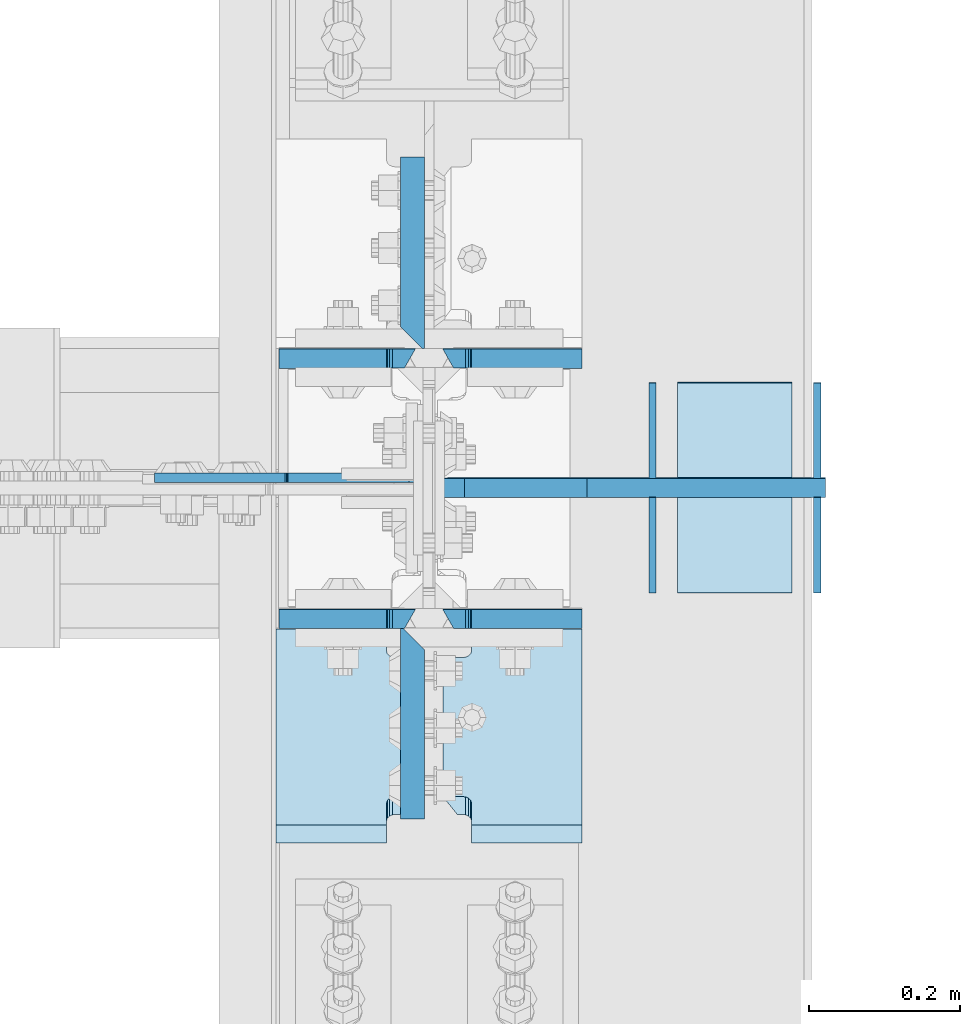
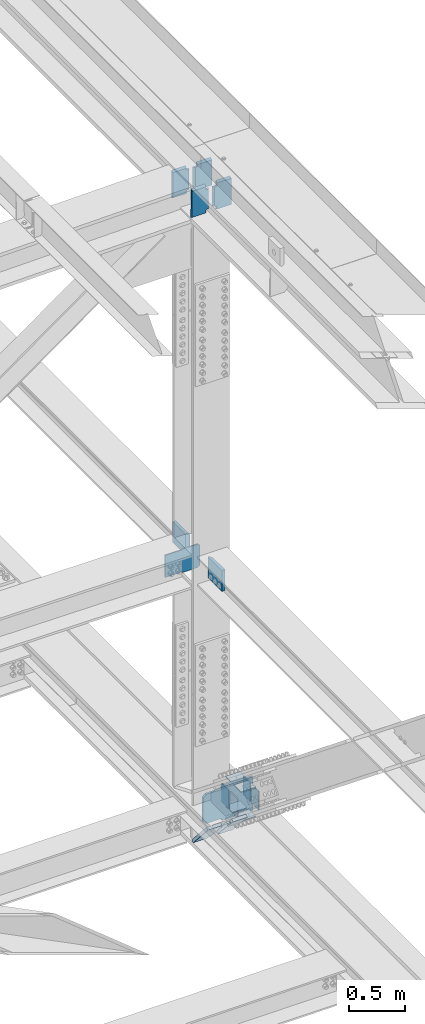
# One storey, part 3594 of 3843: 18 plates, 11 elements without a shape of their own.
"""IFC2X3 building model written with IfcOpenShell, lengths in millimetres."""

from ifc_helpers import new_model, si_unit, frame, origin_with_axes, place, context, subcontext, project, spatial, faceted_brep, material, type_object, element, aggregate, save


model = new_model("IFC2X3")

# Units and contexts
model_context = context("Model", 3, precision=1e-05, world=origin_with_axes())
body_context = subcontext(model_context, "Body", "Model", "MODEL_VIEW")
ifc_project = project(units=[si_unit("LENGTHUNIT", "METRE", prefix="MILLI"), si_unit("AREAUNIT", "SQUARE_METRE"), si_unit("VOLUMEUNIT", "CUBIC_METRE"), si_unit("MASSUNIT", "GRAM", prefix="KILO"), si_unit("TIMEUNIT", "SECOND"), si_unit("PLANEANGLEUNIT", "RADIAN"), si_unit("SOLIDANGLEUNIT", "STERADIAN"), si_unit("THERMODYNAMICTEMPERATUREUNIT", "DEGREE_CELSIUS"), si_unit("LUMINOUSINTENSITYUNIT", "LUMEN")], contexts=[model_context])

# Site, building, storey
site_placement = place(None, origin_with_axes())
site = spatial("IfcSite", under=ifc_project, at=site_placement, CompositionType="ELEMENT")
building_placement = place(site_placement, origin_with_axes())
building = spatial("IfcBuilding", under=site, at=building_placement, Name="Undefined", CompositionType="ELEMENT")
storey_placement = place(building_placement, origin_with_axes())
storey = spatial("IfcBuildingStorey", under=building, at=storey_placement, Name="Undefined", CompositionType="ELEMENT", Elevation=0.0)

# Assembly, plates
assembly_1_placement = place(storey_placement, origin_with_axes())
assembly_1 = element("IfcElementAssembly", 1, at=assembly_1_placement, inside=storey, Name="BEAM", AssemblyPlace="NOTDEFINED", PredefinedType="RIGID_FRAME")
ifc_material = material(Name="STEEL/A572-50")
plate_type_1 = type_object("IfcPlateType", PredefinedType="NOTDEFINED")
plate_1_placement = place(assembly_1_placement, frame((85852.0, 42028.8956526113, 46143.804752739), z_axis=(0.0, -0.00329766299899347, 0.99999456269459), x_axis=(-1.0, 0.0, 0.0)))
plate_1 = element("IfcPlate", 2, at=plate_1_placement, type_object=plate_type_1, material=ifc_material, Name="PLATE", context=body_context, shape_type="Brep", body=[
    faceted_brep([(146.843749999985, -12.7000000010667, 314.312938157032), (146.843749999985, 12.6999999988984, 299.821446398484), (0.0, 12.6999999988984, 299.821446398484), (0.0, -12.7000000010667, 314.312938157032), (146.843749999985, 12.7000000000553, 14.4914917584392), (146.843749999985, -12.7000000000844, 2.18278728425503e-11), (0.0, -12.6999999999971, 0.0), (0.0, 12.7000000000698, 14.4914917390415), (146.843749999985, 12.6999999999098, 38.1890602041385), (146.843749999985, -12.7000000001572, 38.1003132816259), (147.810479922569, 12.6999999998952, 43.0491693876829), (147.810479922569, -12.7000000001644, 42.9604224651703), (150.563493823051, 12.6999999998734, 47.169371005024), (150.563493823051, -12.7000000001863, 47.0806240825113), (154.683670291211, 12.6999999998734, 49.9224017096567), (154.683670291211, -12.7000000001935, 49.833654787144), (159.543749809251, 12.6999999998661, 50.8891375330786), (159.543749809251, -12.7000000001935, 50.800390610566), (170.452258242993, 12.700000000099, 50.8891375249077), (184.943749999991, -12.7000000000116, 50.8003906183731), (184.943749999991, -12.6999999997643, 263.417469235843), (170.452258242993, 12.7000000003609, 263.506216142385), (159.543749809251, 12.6999999992186, 263.506216155103), (159.543749809251, -12.7000000008484, 263.417469232591), (154.683670291211, 12.6999999992113, 264.472951978518), (154.683670291211, -12.7000000008557, 264.384205056005), (150.563493823051, 12.699999999204, 267.225982683158), (150.563493823051, -12.7000000008629, 267.137235760645), (147.810479922569, 12.6999999991895, 271.346184300499), (147.810479922569, -12.7000000008702, 271.257437377986), (146.843749999985, 12.6999999991749, 276.206293484036), (146.843749999985, -12.7000000008848, 276.117546561523)], [[[0, 1, 2, 3]], [[4, 5, 6, 7]], [[8, 9, 5, 4]], [[9, 8, 10, 11]], [[11, 10, 12, 13]], [[13, 12, 14, 15]], [[15, 14, 16, 17]], [[17, 16, 18, 19]], [[20, 19, 18, 21]], [[22, 23, 20, 21]], [[23, 22, 24, 25]], [[25, 24, 26, 27]], [[27, 26, 28, 29]], [[29, 28, 30, 31]], [[6, 5, 9, 11, 13, 15, 17, 19, 20, 23, 25, 27, 29, 31, 0, 3]], [[7, 6, 3, 2]], [[30, 28, 26, 24, 22, 21, 18, 16, 14, 12, 10, 8, 4, 7, 2, 1]], [[31, 30, 1, 0]]]),
])
plate_2_placement = place(assembly_1_placement, frame((85852.0, 42374.9692625149, 46144.7969109018), z_axis=(0.0, -0.00329766299899347, 0.99999456269459), x_axis=(-1.0, 0.0, 0.0)))
plate_2 = element("IfcPlate", 3, at=plate_2_placement, type_object=plate_type_1, material=ifc_material, Name="PLATE", context=body_context, shape_type="Brep", body=[
    faceted_brep([(146.843749999985, -12.7000000001572, 38.1003132816259), (146.843749999985, 12.6999999999098, 38.1890602041385), (147.810479922569, 12.6999999998952, 43.0491693876829), (147.810479922569, -12.7000000001644, 42.9604224651703), (150.563493823051, 12.6999999998734, 47.169371005024), (150.563493823051, -12.7000000001863, 47.0806240825113), (154.683670291211, 12.6999999998734, 49.9224017096567), (154.683670291211, -12.7000000001935, 49.833654787144), (159.543749809251, 12.6999999998661, 50.8891375330786), (159.543749809251, -12.7000000001935, 50.800390610566), (170.452258242993, 12.700000000099, 50.8891375249077), (184.943749999991, -12.7000000000116, 50.8003906183731), (184.943749999991, -12.6999999997643, 263.417469235843), (170.452258242993, 12.7000000003609, 263.506216142385), (159.543749809251, 12.6999999992186, 263.506216155103), (159.543749809251, -12.7000000008484, 263.417469232591), (154.683670291211, 12.6999999992113, 264.472951978518), (154.683670291211, -12.7000000008557, 264.384205056005), (150.563493823051, 12.699999999204, 267.225982683158), (150.563493823051, -12.7000000008629, 267.137235760645), (147.810479922569, 12.6999999991895, 271.346184300499), (147.810479922569, -12.7000000008702, 271.257437377986), (146.843749999985, 12.6999999991749, 276.206293484036), (146.843749999985, -12.7000000008848, 276.117546561523), (146.843749999985, -12.7000000010376, 304.032321860701), (146.843749999985, 12.6999999989348, 289.540830114318), (0.0, 12.6999999989348, 289.540830114318), (0.0, -12.7000000010376, 304.032321860701), (0.0, -12.6999999999971, 0.0), (146.843749999985, -12.7000000000844, 2.18278728425503e-11), (146.843749999985, 12.7000000000553, 14.4914917584392), (0.0, 12.7000000000698, 14.4914917390415)], [[[0, 1, 2, 3]], [[3, 2, 4, 5]], [[5, 4, 6, 7]], [[7, 6, 8, 9]], [[9, 8, 10, 11]], [[12, 11, 10, 13]], [[14, 15, 12, 13]], [[15, 14, 16, 17]], [[17, 16, 18, 19]], [[19, 18, 20, 21]], [[21, 20, 22, 23]], [[24, 23, 22, 25]], [[26, 27, 24, 25]], [[0, 3, 5, 7, 9, 11, 12, 15, 17, 19, 21, 23, 24, 27, 28, 29]], [[1, 0, 29, 30]], [[26, 25, 22, 20, 18, 16, 14, 13, 10, 8, 6, 4, 2, 1, 30, 31]], [[27, 26, 31, 28]], [[30, 29, 28, 31]]]),
])

# Assembly, plate
assembly_2_placement = place(storey_placement, origin_with_axes())
assembly_2 = element("IfcElementAssembly", 4, at=assembly_2_placement, inside=storey, Name="COLUMN", AssemblyPlace="NOTDEFINED", PredefinedType="RIGID_FRAME")
plate_type_2 = type_object("IfcPlateType", PredefinedType="NOTDEFINED")
plate_3_placement = place(assembly_2_placement, frame((85640.8624999999, 42215.5937500954, 42192.0789969217), z_axis=(-0.707106781186548, 0.0, 0.707106781186548), x_axis=(-0.707106781186548, 0.0, -0.707106781186548)))
plate_3 = element("IfcPlate", 5, at=plate_3_placement, type_object=plate_type_2, material=ifc_material, Name="PLATE", context=body_context, shape_type="Brep", body=[
    faceted_brep([(0.0, -6.3499999046162, 0.0), (-152.665587827403, -6.34999999999854, 152.665587827403), (-152.665587827403, 6.34999999999854, 152.665587827403), (7.27595761418343e-12, 6.3499999046162, 0.0), (-152.665587827112, -6.34999999999854, 179.606356190761), (-152.665587827112, 6.34999999999854, 179.606356190761), (-39.2898544208874, -6.34999999999854, 292.982089845096), (-39.2898544208874, 6.34999999999854, 292.982089845096), (-37.2519695532828, -6.34999999999854, 291.620418710037), (-37.2519695532828, 6.34999999999854, 291.620418710037), (-34.8481204507552, -6.34999999999854, 291.142263394238), (-34.8481204507552, 6.34999999999854, 291.142263394238), (-32.4442713482422, -6.34999999999854, 291.620418710056), (-32.4442713482422, 6.34999999999854, 291.620418710056), (-30.406386480623, -6.34999999999854, 292.98208984514), (-30.406386480623, 6.34999999999854, 292.98208984514), (90.8754652461794, -6.34999999999854, 414.263941571935), (90.8754652461794, 6.34999999999854, 414.263941571935), (261.500331545671, -6.34999999999854, 243.639075272451), (261.500331545671, 6.34999999999854, 243.639075272451), (140.316501924579, -6.34999999999854, 122.455245651345), (140.316501924579, 6.34999999999854, 122.455245651345), (138.924780842135, -6.34999999999854, 120.372387859356), (138.924780842135, 6.34999999999854, 120.372387859356), (138.436073388089, -6.34999999999854, 117.915489575513), (138.436073388089, 6.34999999999854, 117.915489575513), (138.924780842121, -6.34999999999854, 115.458591291659), (138.924780842121, 6.34999999999854, 115.458591291659), (140.316501893642, -6.34999999999854, 113.375733530571), (140.316501893642, 6.34999999999854, 113.375733530571), (26.9407683632217, -6.34999999999854, 1.30967237055302e-10), (26.9407683632217, 6.34999999999854, 1.30967237055302e-10)], [[[0, 1, 2, 3]], [[1, 4, 5, 2]], [[4, 6, 7, 5]], [[6, 8, 9, 7]], [[8, 10, 11, 9]], [[10, 12, 13, 11]], [[12, 14, 15, 13]], [[14, 16, 17, 15]], [[16, 18, 19, 17]], [[18, 20, 21, 19]], [[20, 22, 23, 21]], [[22, 24, 25, 23]], [[24, 26, 27, 25]], [[26, 28, 29, 27]], [[28, 30, 31, 29]], [[30, 0, 3, 31]], [[5, 7, 9, 11, 13, 15, 17, 19, 21, 23, 25, 27, 29, 31, 3, 2]], [[30, 28, 26, 24, 22, 20, 18, 16, 14, 12, 10, 8, 6, 4, 1, 0]]]),
])

# Plate
plate_type_3 = type_object("IfcPlateType", PredefinedType="NOTDEFINED")
plate_4_placement = place(assembly_1_placement, frame((85630.54375, 42028.8956526113, 46143.804752739), z_axis=(0.0, -0.00329766299899347, 0.99999456269459), x_axis=(-1.0, 0.0, 0.0)))
plate_4 = element("IfcPlate", 6, at=plate_4_placement, type_object=plate_type_3, material=ifc_material, Name="PLATE", context=body_context, shape_type="Brep", body=[
    faceted_brep([(180.974999999991, 12.7000000000553, 14.4914917584392), (180.974999999991, -12.7000000000844, 2.18278728425503e-11), (38.1000000000058, -12.7000000000844, 2.18278728425503e-11), (38.1000000000058, 12.7000000000553, 14.4914917584392), (37.1332700774219, -12.7000000001644, 42.9604224651848), (37.1332700774219, 12.6999999998952, 43.0491693876975), (38.1000000000058, 12.6999999999098, 38.1890602041531), (38.1000000000058, -12.7000000001572, 38.1003132816404), (34.3802561769407, -12.7000000001863, 47.0806240825259), (34.3802561769407, 12.6999999998734, 47.1693710050386), (30.2600797087798, -12.7000000001935, 49.8336547871586), (30.2600797087798, 12.6999999998734, 49.9224017096712), (25.4000001907407, -12.7000000001935, 50.8003906105805), (25.4000001907407, 12.6999999998661, 50.8891375330932), (0.0, -12.7000000000262, 50.8003906045633), (14.4914917569986, 12.7000000001135, 50.8891375364256), (14.4914917569986, 12.7000000003463, 263.506216154878), (0.0, -12.6999999997643, 263.417469223023), (25.4000001907407, -12.7000000008484, 263.417469232605), (25.4000001907407, 12.6999999992186, 263.506216155118), (30.2600797087798, -12.7000000008557, 264.38420505602), (30.2600797087798, 12.6999999992113, 264.472951978532), (34.3802561769407, -12.7000000008629, 267.13723576066), (34.3802561769407, 12.699999999204, 267.225982683172), (37.1332700774219, -12.7000000008702, 271.257437378001), (37.1332700774219, 12.6999999991895, 271.346184300513), (38.1000000000058, -12.7000000008848, 276.117546561538), (38.1000000000058, 12.6999999991749, 276.206293484051), (38.1000000000058, -12.6996273309633, 314.217780603329), (38.1000000000058, 12.6999999988984, 299.821446398484), (180.974999999991, -12.7000000010667, 314.312938157032), (180.974999999991, 12.6999999988984, 299.821446398484)], [[[0, 1, 2, 3]], [[4, 5, 6, 7]], [[8, 9, 5, 4]], [[10, 11, 9, 8]], [[12, 13, 11, 10]], [[13, 12, 14, 15]], [[16, 15, 14, 17]], [[18, 19, 16, 17]], [[20, 21, 19, 18]], [[22, 23, 21, 20]], [[24, 25, 23, 22]], [[26, 27, 25, 24]], [[27, 26, 28, 29]], [[30, 31, 29, 28]], [[6, 5, 9, 11, 13, 15, 16, 19, 21, 23, 25, 27, 29, 31, 0, 3]], [[7, 6, 3, 2]], [[30, 28, 26, 24, 22, 20, 18, 17, 14, 12, 10, 8, 4, 7, 2, 1]], [[31, 30, 1, 0]]]),
])

plate_5_placement = place(assembly_1_placement, frame((85630.54375, 42374.9692625149, 46144.7969109018), z_axis=(0.0, -0.00329766299899347, 0.99999456269459), x_axis=(-1.0, 0.0, 0.0)))
plate_5 = element("IfcPlate", 7, at=plate_5_placement, type_object=plate_type_3, material=ifc_material, Name="PLATE", context=body_context, shape_type="Brep", body=[
    faceted_brep([(180.974999999991, 12.7000000000553, 14.4914917584392), (180.974999999991, -12.7000000000844, 2.18278728425503e-11), (38.1000000000058, -12.7000000000844, 2.18278728425503e-11), (38.1000000000058, 12.7000000000553, 14.4914917584392), (37.1332700774219, -12.7000000001644, 42.9604224651848), (37.1332700774219, 12.6999999998952, 43.0491693876975), (38.1000000000058, 12.6999999999098, 38.1890602041531), (38.1000000000058, -12.7000000001572, 38.1003132816404), (34.3802561769407, -12.7000000001863, 47.0806240825259), (34.3802561769407, 12.6999999998734, 47.1693710050386), (30.2600797087798, -12.7000000001935, 49.8336547871586), (30.2600797087798, 12.6999999998734, 49.9224017096712), (25.4000001907407, -12.7000000001935, 50.8003906105805), (25.4000001907407, 12.6999999998661, 50.8891375330932), (0.0, -12.7000000000262, 50.8003906045633), (14.4914917569986, 12.7000000001135, 50.8891375364256), (14.4914917569986, 12.7000000003463, 263.506216154878), (0.0, -12.6999999997643, 263.417469223023), (25.4000001907407, -12.7000000008484, 263.417469232605), (25.4000001907407, 12.6999999992186, 263.506216155118), (30.2600797087798, -12.7000000008557, 264.38420505602), (30.2600797087798, 12.6999999992113, 264.472951978532), (34.3802561769407, -12.7000000008629, 267.13723576066), (34.3802561769407, 12.699999999204, 267.225982683172), (37.1332700774219, -12.7000000008702, 271.257437378001), (37.1332700774219, 12.6999999991895, 271.346184300513), (38.1000000000058, -12.7000000008848, 276.117546561538), (38.1000000000058, 12.6999999991749, 276.206293484051), (38.1000000000058, -12.7000000010376, 304.032321860686), (38.1000000000058, 12.6999999989348, 289.540830114303), (180.974999999991, -12.7000000010376, 304.032321860686), (180.974999999991, 12.6999999989348, 289.540830114303)], [[[0, 1, 2, 3]], [[4, 5, 6, 7]], [[8, 9, 5, 4]], [[10, 11, 9, 8]], [[12, 13, 11, 10]], [[13, 12, 14, 15]], [[16, 15, 14, 17]], [[18, 19, 16, 17]], [[20, 21, 19, 18]], [[22, 23, 21, 20]], [[24, 25, 23, 22]], [[26, 27, 25, 24]], [[28, 29, 27, 26]], [[30, 31, 29, 28]], [[6, 5, 9, 11, 13, 15, 16, 19, 21, 23, 25, 27, 29, 31, 0, 3]], [[7, 6, 3, 2]], [[30, 28, 26, 24, 22, 20, 18, 17, 14, 12, 10, 8, 4, 7, 2, 1]], [[31, 30, 1, 0]]]),
])

aggregate(assembly_1, [plate_1, plate_4, plate_2, plate_5])

# Assembly, plates
assembly_3_placement = place(storey_placement, origin_with_axes())
assembly_3 = element("IfcElementAssembly", 8, at=assembly_3_placement, inside=storey, Name="BEAM", AssemblyPlace="NOTDEFINED", PredefinedType="RIGID_FRAME")
plate_type_4 = type_object("IfcPlateType", PredefinedType="NOTDEFINED")
plate_6_placement = place(assembly_3_placement, frame((85852.0, 41742.5415319172, 39674.1329955705), z_axis=(0.0, 0.663164085108576, -0.748474045122545), x_axis=(-1.0, 0.0, 0.0)))
plate_6 = element("IfcPlate", 9, at=plate_6_placement, type_object=plate_type_4, material=ifc_material, Name="PLATE", context=body_context, shape_type="Brep", body=[
    faceted_brep([(165.893749999988, -15.8750000001892, 57.1497682512127), (184.943749999991, 15.8749999999127, 57.1499051690625), (184.943743896481, 15.8749999992579, 335.346266448745), (165.893743896479, -15.8750000008476, 335.346018382654), (154.683905942948, -15.8750000001892, 56.1831013699993), (154.683905942948, 15.8749999999127, 56.1833494360908), (159.543996806155, 15.8749999999127, 57.1500533652579), (159.543996806155, -15.8750000001892, 57.149805299181), (150.563710384493, -15.8750000001783, 53.430105139385), (150.563710384493, 15.8749999999127, 53.4303532054619), (147.810674088149, -15.8750000001746, 49.3099363519141), (147.810674088149, 15.8749999999345, 49.3101844180055), (146.843922898159, -15.8750000001637, 44.4498548893025), (146.843922898159, 15.8749999999418, 44.450102955394), (146.843749999985, -15.8750000000582, -1.30967237055302e-10), (146.843749999985, 15.8750000000437, 1.01863406598568e-10), (0.0, -15.875, 0.0), (0.0, 15.875, 0.0), (0.0, -15.875000000975, 392.496138987422), (0.0, 15.8749999991305, 392.496138987655), (146.843966194254, -15.875000000975, 392.496138987422), (146.843966194254, 15.8749999991305, 392.496138987655), (146.843793296168, -15.8750000008731, 348.046067591757), (146.843793296168, 15.8749999992287, 348.046315657848), (147.810509040442, -15.8750000008586, 343.185972903491), (147.810509040442, 15.8749999992469, 343.186220969583), (150.563519653791, -15.8750000008476, 339.065779671204), (150.563519653791, 15.8749999992542, 339.066027737295), (154.683702177499, -15.875000000844, 336.312753031365), (154.683702177499, 15.8749999992651, 336.313001097456), (159.543793105346, -15.8750000008476, 335.346018382654), (159.543793105346, 15.8749999992579, 335.346266448745)], [[[0, 1, 2, 3]], [[4, 5, 6, 7]], [[8, 9, 5, 4]], [[10, 11, 9, 8]], [[12, 13, 11, 10]], [[14, 15, 13, 12]], [[16, 17, 15, 14]], [[16, 18, 19, 17]], [[19, 18, 20, 21]], [[20, 22, 23, 21]], [[24, 25, 23, 22]], [[26, 27, 25, 24]], [[28, 29, 27, 26]], [[30, 31, 29, 28]], [[31, 30, 3, 2]], [[6, 5, 9, 11, 13, 15, 17, 19, 21, 23, 25, 27, 29, 31, 2, 1]], [[7, 6, 1, 0]], [[30, 28, 26, 24, 22, 20, 18, 16, 14, 12, 10, 8, 4, 7, 0, 3]]]),
])
plate_7_placement = place(assembly_3_placement, frame((85633.71875, 41742.5415319172, 39674.1329955706), z_axis=(0.0, 0.663164085108576, -0.748474045122545), x_axis=(-1.0, 0.0, 0.0)))
plate_7 = element("IfcPlate", 10, at=plate_7_placement, type_object=plate_type_4, material=ifc_material, Name="PLATE", context=body_context, shape_type="Brep", body=[
    faceted_brep([(3.17499999998836, 15.8749999999127, 57.1501274642651), (22.2250000000931, -15.8750000005602, 57.1497682499321), (22.224777702213, -15.8750000008295, 335.346018381068), (3.17477770221012, 15.8749999992724, 335.346266447174), (28.5748519917834, -15.8750000005602, 57.1497312013817), (28.5748519917834, 15.87499999992, 57.1499792674585), (33.4349087547453, 15.87499999992, 56.183228077658), (33.4349087547453, -15.8750000005748, 56.1829800115665), (37.5550600770075, 15.8749999999309, 53.4302092465805), (37.5550600770075, -15.8750000005712, 53.4299611805036), (40.308054868714, 15.8749999999382, 49.3100418616523), (40.308054868714, -15.8750000005821, 49.3097937955754), (41.2747777022159, 15.8749999999491, 44.4499794580915), (41.2747777022159, -15.8750000005894, 44.4497313920001), (41.2747777022159, 15.8750000000582, 1.01863406598568e-10), (41.2747777022159, -15.8750000000291, 2.91038304567337e-11), (188.118743896484, 15.8750000000582, 1.01863406598568e-10), (188.118743896484, -15.8750000000509, -1.16415321826935e-10), (188.118743896484, -15.875000000975, 392.496138987379), (188.118743896484, 15.8749999991378, 392.496138987612), (41.2747777022159, 15.8749999991378, 392.496138987612), (41.2747777022159, -15.8749999982901, 392.495796089381), (41.2747777022159, 15.8749999992469, 348.046266256773), (41.2747777022159, -15.8750000008586, 348.046018190682), (40.308047779632, 15.8749999992579, 343.186186738589), (40.308047779632, -15.8750000008513, 343.185938672512), (37.5550338791509, 15.8749999992579, 339.066010270326), (37.5550338791509, -15.875000000844, 339.065762204249), (33.4348574109899, 15.8749999992651, 336.312996369772), (33.4348574109899, -15.8750000008367, 336.312748303695), (28.5747778929508, 15.8749999992724, 335.346266447174), (28.5747778929508, -15.8750000008295, 335.346018381068)], [[[0, 1, 2, 3]], [[4, 5, 6, 7]], [[7, 6, 8, 9]], [[9, 8, 10, 11]], [[11, 10, 12, 13]], [[13, 12, 14, 15]], [[16, 17, 15, 14]], [[18, 17, 16, 19]], [[18, 19, 20, 21]], [[21, 20, 22, 23]], [[23, 22, 24, 25]], [[25, 24, 26, 27]], [[27, 26, 28, 29]], [[29, 28, 30, 31]], [[4, 7, 9, 11, 13, 15, 17, 18, 21, 23, 25, 27, 29, 31, 2, 1]], [[5, 4, 1, 0]], [[30, 28, 26, 24, 22, 20, 19, 16, 14, 12, 10, 8, 6, 5, 0, 3]], [[31, 30, 3, 2]]]),
])
plate_type_5 = type_object("IfcPlateType", PredefinedType="NOTDEFINED")
plate_8_placement = place(assembly_3_placement, frame((86175.8500000045, 42203.2815932076, 39345.032364924), z_axis=(0.0, -0.00349395200045545, 0.999993896131081), x_axis=(-1.0, 0.0, 0.0)))
plate_8 = element("IfcPlate", 11, at=plate_8_placement, type_object=plate_type_5, material=ifc_material, Name="STIFFENER", context=body_context, shape_type="Brep", body=[
    faceted_brep([(0.0, -12.6999999999971, 0.0), (1.43627403303981e-08, -12.7000000003172, 368.282421855467), (1.43627403303981e-08, 12.6999999996769, 368.282421855489), (0.0, 12.6999999999971, 0.0), (317.500000026223, -12.7000000003172, 368.282421839234), (317.500000026223, 12.6999999996769, 368.282421839256), (317.500000024767, -12.7000000002881, 342.88242181766), (317.500000024767, 12.6999999996915, 342.882421817681), (480.218749970372, -12.7000000002881, 342.882421787188), (480.218749970372, 12.6999999996915, 342.88242178721), (511.968749969019, -12.700000000259, 311.132421781258), (511.968749969019, 12.6999999997206, 311.132421781287), (511.968749958221, -12.7000000000553, 57.1500000187953), (511.968749958221, 12.6999999999389, 57.1500000188171), (480.218749956868, -12.7000000000116, 25.4000000166852), (480.218749956868, 12.6999999999825, 25.4000000167216), (317.500000000146, -12.7000000000116, 25.4000000058295), (317.500000000146, 12.699999999968, 25.4000000058659), (317.50000000211, -12.6999999999971, -8.14907252788544e-10), (317.50000000211, 12.6999999999971, -7.93079379945993e-10)], [[[0, 1, 2, 3]], [[1, 4, 5, 2]], [[4, 6, 7, 5]], [[6, 8, 9, 7]], [[8, 10, 11, 9]], [[10, 12, 13, 11]], [[12, 14, 15, 13]], [[14, 16, 17, 15]], [[16, 18, 19, 17]], [[18, 0, 3, 19]], [[5, 7, 9, 11, 13, 15, 17, 19, 3, 2]], [[18, 16, 14, 12, 10, 8, 6, 4, 1, 0]]]),
])
aggregate(assembly_3, [plate_6, plate_7, plate_8])

# Plate
plate_type_6 = type_object("IfcPlateType", PredefinedType="NOTDEFINED")
plate_9_placement = place(assembly_2_placement, frame((85626.575, 42387.8374999982, 42414.2200670874), z_axis=(0.0, 1.0, 0.0), x_axis=(0.0, 0.0, -1.0)))
plate_9 = element("IfcPlate", 12, at=plate_9_placement, type_object=plate_type_6, material=ifc_material, Name="PLATE", context=body_context, shape_type="Brep", body=[
    faceted_brep([(228.600000000064, 15.875, 28.5750007623283), (228.599999999991, -12.7000007629103, -5.82076609134674e-10), (0.0, -12.6999999999971, 0.0), (6.54836185276508e-11, 15.875, 28.5750007629249), (0.0, -15.875, 0.0), (6.69388100504875e-10, -15.875, 254.0), (6.69388100504875e-10, 15.875, 254.0), (228.600000000668, -15.875, 253.999999999403), (228.600000000668, 15.875, 253.999999999403), (228.599999999991, -15.875, -5.82076609134674e-10)], [[[0, 1, 2, 3]], [[4, 5, 6, 3, 2]], [[5, 7, 8, 6]], [[8, 7, 9, 1, 0]], [[9, 4, 2, 1]], [[6, 8, 0, 3]], [[9, 7, 5, 4]]]),
])

plate_10_placement = place(assembly_2_placement, frame((85626.5751061595, 42016.3624999984, 42412.8635017606), z_axis=(0.0, -1.0, 0.0), x_axis=(0.0, 0.0, -1.0)))
plate_10 = element("IfcPlate", 13, at=plate_10_placement, type_object=plate_type_6, material=ifc_material, Name="PLATE", context=body_context, shape_type="Brep", body=[
    faceted_brep([(228.600000000064, 15.875, 28.5750007623283), (228.599999999991, -12.700106944947, 5.96628524363041e-10), (-7.27595761418343e-12, -12.700106944947, -1.45519152283669e-11), (6.54836185276508e-11, 15.875, 28.5750007629249), (0.0, -15.875, 0.0), (6.69388100504875e-10, -15.875, 254.0), (6.69388100504875e-10, 15.875, 254.0), (228.600000000668, -15.875, 253.999999999403), (228.600000000668, 15.875, 253.999999999403), (228.599999999991, -15.875, -5.82076609134674e-10)], [[[0, 1, 2, 3]], [[4, 5, 6, 3, 2]], [[5, 7, 8, 6]], [[8, 7, 9, 1, 0]], [[9, 4, 2, 1]], [[6, 8, 0, 3]], [[9, 7, 5, 4]]]),
])

aggregate(assembly_2, [plate_9, plate_3, plate_10])

# Assembly, plate
assembly_4_placement = place(storey_placement, origin_with_axes())
assembly_4 = element("IfcElementAssembly", 14, at=assembly_4_placement, inside=storey, Name="PLATE", AssemblyPlace="NOTDEFINED", PredefinedType="RIGID_FRAME")
plate_type_7 = type_object("IfcPlateType", PredefinedType="NOTDEFINED")
plate_11_placement = place(assembly_4_placement, frame((85945.6625, 42189.6367781656, 39632.3558716309), z_axis=(0.0, -0.999997287130488, -0.00232932000032452), x_axis=(0.0, 0.0023293200003218, -0.999997287130488)))
plate_11 = element("IfcPlate", 15, at=plate_11_placement, type_object=plate_type_7, material=ifc_material, Name="PLATE", context=body_context, shape_type="Brep", body=[
    faceted_brep([(0.0, -4.76249999999709, 0.0), (0.0591655253520003, -4.76249999999709, 126.999862184552), (0.0591655253520003, 4.76249999999709, 126.999862184552), (0.0, 4.76249999999709, 0.0), (203.258958801976, -4.76249999999709, 126.999862185381), (203.258958801976, 4.76249999999709, 126.999862185381), (203.199767438149, -4.76249999999709, 3.78349795937538e-10), (203.199767438149, 4.76249999999709, 3.78349795937538e-10)], [[[0, 1, 2, 3]], [[1, 4, 5, 2]], [[4, 6, 7, 5]], [[6, 0, 3, 7]], [[5, 7, 3, 2]], [[6, 4, 1, 0]]]),
])
aggregate(assembly_4, [plate_11])

assembly_5_placement = place(storey_placement, origin_with_axes())
assembly_5 = element("IfcElementAssembly", 16, at=assembly_5_placement, inside=storey, Name="PLATE", AssemblyPlace="NOTDEFINED", PredefinedType="RIGID_FRAME")
plate_12_placement = place(assembly_5_placement, frame((86164.7375000001, 42189.6367781655, 39632.3558716309), z_axis=(0.0, -0.999997287130488, -0.00232932000032452), x_axis=(0.0, 0.0023293200003218, -0.999997287130488)))
plate_12 = element("IfcPlate", 17, at=plate_12_placement, type_object=plate_type_7, material=ifc_material, Name="PLATE", context=body_context, shape_type="Brep", body=[
    faceted_brep([(0.0, -4.76249999999709, 0.0), (0.0591655253520003, -4.76249999999709, 126.999862184552), (0.0591655253520003, 4.76249999999709, 126.999862184552), (0.0, 4.76249999999709, 0.0), (203.258958801976, -4.76249999999709, 126.999862185381), (203.258958801976, 4.76249999999709, 126.999862185381), (203.199767438149, -4.76249999999709, 3.78349795937538e-10), (203.199767438149, 4.76249999999709, 3.78349795937538e-10)], [[[0, 1, 2, 3]], [[1, 4, 5, 2]], [[4, 6, 7, 5]], [[6, 0, 3, 7]], [[5, 7, 3, 2]], [[6, 4, 1, 0]]]),
])
aggregate(assembly_5, [plate_12])

assembly_6_placement = place(storey_placement, origin_with_axes())
assembly_6 = element("IfcElementAssembly", 18, at=assembly_6_placement, inside=storey, Name="PLATE", AssemblyPlace="NOTDEFINED", PredefinedType="RIGID_FRAME")
plate_13_placement = place(assembly_6_placement, frame((86131.4000000045, 42190.4832276682, 39371.893138382), z_axis=(0.0, -0.999996093451593, -0.0027951890012555), x_axis=(-1.0, 0.0, 0.0)))
plate_13 = element("IfcPlate", 19, at=plate_13_placement, type_object=plate_type_7, material=ifc_material, Name="PLATE", context=body_context, shape_type="Brep", body=[
    faceted_brep([(0.0, -4.76249999999709, 0.0), (-5.82076609134674e-11, -4.76249999972788, 126.999999995154), (-5.82076609134674e-11, 4.76250000024447, 126.999999995183), (0.0, 4.76249999999709, 0.0), (152.399999999951, -4.76249999972788, 126.999999995154), (152.399999999951, 4.76250000024447, 126.999999995183), (152.399993896484, -4.76249999999709, 0.0), (152.399993896484, 4.76249999999709, 0.0)], [[[0, 1, 2, 3]], [[1, 4, 5, 2]], [[4, 6, 7, 5]], [[6, 0, 3, 7]], [[5, 7, 3, 2]], [[6, 4, 1, 0]]]),
])
aggregate(assembly_6, [plate_13])

assembly_7_placement = place(storey_placement, origin_with_axes())
assembly_7 = element("IfcElementAssembly", 20, at=assembly_7_placement, inside=storey, Name="PLATE", AssemblyPlace="NOTDEFINED", PredefinedType="RIGID_FRAME")
plate_14_placement = place(assembly_7_placement, frame((86131.4000000045, 42189.3799909081, 39689.3912782581), z_axis=(0.0, -0.999993896022768, -0.00349398300008034), x_axis=(-1.0, 0.0, 0.0)))
plate_14 = element("IfcPlate", 21, at=plate_14_placement, type_object=plate_type_7, material=ifc_material, Name="PLATE", context=body_context, shape_type="Brep", body=[
    faceted_brep([(0.0, -4.76249999999709, 0.0), (-5.82076609134674e-11, -4.76249999972788, 126.999999995154), (-5.82076609134674e-11, 4.76250000024447, 126.999999995183), (0.0, 4.76249999999709, 0.0), (152.399999999951, -4.76249999972788, 126.999999995154), (152.399999999951, 4.76250000024447, 126.999999995183), (152.399993896484, -4.76249999999709, 0.0), (152.399993896484, 4.76249999999709, 0.0)], [[[0, 1, 2, 3]], [[1, 4, 5, 2]], [[4, 6, 7, 5]], [[6, 0, 3, 7]], [[5, 7, 3, 2]], [[6, 4, 1, 0]]]),
])
aggregate(assembly_7, [plate_14])

assembly_8_placement = place(storey_placement, origin_with_axes())
assembly_8 = element("IfcElementAssembly", 22, at=assembly_8_placement, inside=storey, Name="PLATE", AssemblyPlace="NOTDEFINED", PredefinedType="RIGID_FRAME")
plate_15_placement = place(assembly_8_placement, frame((85945.6625, 42215.0365756474, 39632.4589490437), z_axis=(0.0, 0.999997287167757, 0.00232930400039185), x_axis=(0.0, 0.0023293200003218, -0.999997287130488)))
plate_15 = element("IfcPlate", 23, at=plate_15_placement, type_object=plate_type_7, material=ifc_material, Name="PLATE", context=body_context, shape_type="Brep", body=[
    faceted_brep([(0.0, -4.76249999999709, 0.0), (-0.0591643335937988, -4.76249999999709, 126.999862189776), (-0.0591643335937988, 4.76249999999709, 126.999862189776), (0.0, 4.76249999999709, 0.0), (203.140628949273, -4.76249999999709, 126.999862188917), (203.140628949273, 4.76249999999709, 126.999862188917), (203.199767438149, -4.76249999999709, 3.78349795937538e-10), (203.199767438149, 4.76249999999709, 3.78349795937538e-10)], [[[0, 1, 2, 3]], [[1, 4, 5, 2]], [[4, 6, 7, 5]], [[6, 0, 3, 7]], [[5, 7, 3, 2]], [[6, 4, 1, 0]]]),
])
aggregate(assembly_8, [plate_15])

assembly_9_placement = place(storey_placement, origin_with_axes())
assembly_9 = element("IfcElementAssembly", 24, at=assembly_9_placement, inside=storey, Name="PLATE", AssemblyPlace="NOTDEFINED", PredefinedType="RIGID_FRAME")
plate_16_placement = place(assembly_9_placement, frame((86164.7375000001, 42215.0365756473, 39632.4589490437), z_axis=(0.0, 0.999997287167757, 0.00232930400039185), x_axis=(0.0, 0.0023293200003218, -0.999997287130488)))
plate_16 = element("IfcPlate", 25, at=plate_16_placement, type_object=plate_type_7, material=ifc_material, Name="PLATE", context=body_context, shape_type="Brep", body=[
    faceted_brep([(0.0, -4.76249999999709, 0.0), (-0.0591643335937988, -4.76249999999709, 126.999862189776), (-0.0591643335937988, 4.76249999999709, 126.999862189776), (0.0, 4.76249999999709, 0.0), (203.140628949273, -4.76249999999709, 126.999862188917), (203.140628949273, 4.76249999999709, 126.999862188917), (203.199767438149, -4.76249999999709, 3.78349795937538e-10), (203.199767438149, 4.76249999999709, 3.78349795937538e-10)], [[[0, 1, 2, 3]], [[1, 4, 5, 2]], [[4, 6, 7, 5]], [[6, 0, 3, 7]], [[5, 7, 3, 2]], [[6, 4, 1, 0]]]),
])
aggregate(assembly_9, [plate_16])

assembly_10_placement = place(storey_placement, origin_with_axes())
assembly_10 = element("IfcElementAssembly", 26, at=assembly_10_placement, inside=storey, Name="PLATE", AssemblyPlace="NOTDEFINED", PredefinedType="RIGID_FRAME")
plate_17_placement = place(assembly_10_placement, frame((86131.4000000045, 42215.8826502163, 39372.1100283535), z_axis=(0.0, 0.99999609352148, 0.00279516399866407), x_axis=(-1.0, 0.0, 0.0)))
plate_17 = element("IfcPlate", 27, at=plate_17_placement, type_object=plate_type_7, material=ifc_material, Name="PLATE", context=body_context, shape_type="Brep", body=[
    faceted_brep([(0.0, -4.76249999999709, 0.0), (-5.82076609134674e-11, -4.76249999972788, 126.999999995154), (-5.82076609134674e-11, 4.76250000024447, 126.999999995183), (0.0, 4.76249999999709, 0.0), (152.399999999951, -4.76249999972788, 126.999999995154), (152.399999999951, 4.76250000024447, 126.999999995183), (152.399993896484, -4.76249999999709, 0.0), (152.399993896484, 4.76249999999709, 0.0)], [[[0, 1, 2, 3]], [[1, 4, 5, 2]], [[4, 6, 7, 5]], [[6, 0, 3, 7]], [[5, 7, 3, 2]], [[6, 4, 1, 0]]]),
])
aggregate(assembly_10, [plate_17])

assembly_11_placement = place(storey_placement, origin_with_axes())
assembly_11 = element("IfcElementAssembly", 28, at=assembly_11_placement, inside=storey, Name="PLATE", AssemblyPlace="NOTDEFINED", PredefinedType="RIGID_FRAME")
plate_18_placement = place(assembly_11_placement, frame((86131.4000000045, 42214.7777525983, 39689.6084280148), z_axis=(0.0, 0.999993896131081, 0.00349395200045545), x_axis=(-1.0, 0.0, 0.0)))
plate_18 = element("IfcPlate", 29, at=plate_18_placement, type_object=plate_type_7, material=ifc_material, Name="PLATE", context=body_context, shape_type="Brep", body=[
    faceted_brep([(0.0, -4.76249999999709, 0.0), (-5.82076609134674e-11, -4.76249999972788, 126.999999995154), (-5.82076609134674e-11, 4.76250000024447, 126.999999995183), (0.0, 4.76249999999709, 0.0), (152.399999999951, -4.76249999972788, 126.999999995154), (152.399999999951, 4.76250000024447, 126.999999995183), (152.399993896484, -4.76249999999709, 0.0), (152.399993896484, 4.76249999999709, 0.0)], [[[0, 1, 2, 3]], [[1, 4, 5, 2]], [[4, 6, 7, 5]], [[6, 0, 3, 7]], [[5, 7, 3, 2]], [[6, 4, 1, 0]]]),
])
aggregate(assembly_11, [plate_18])

save(model, "model.ifc")
